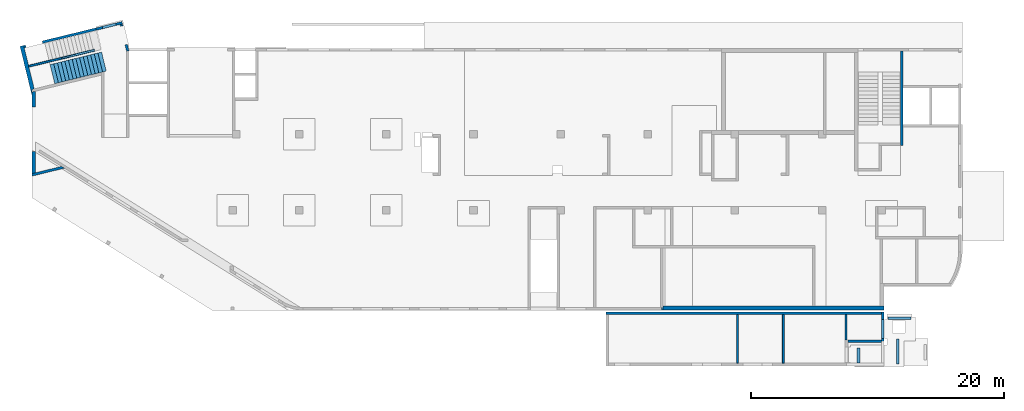
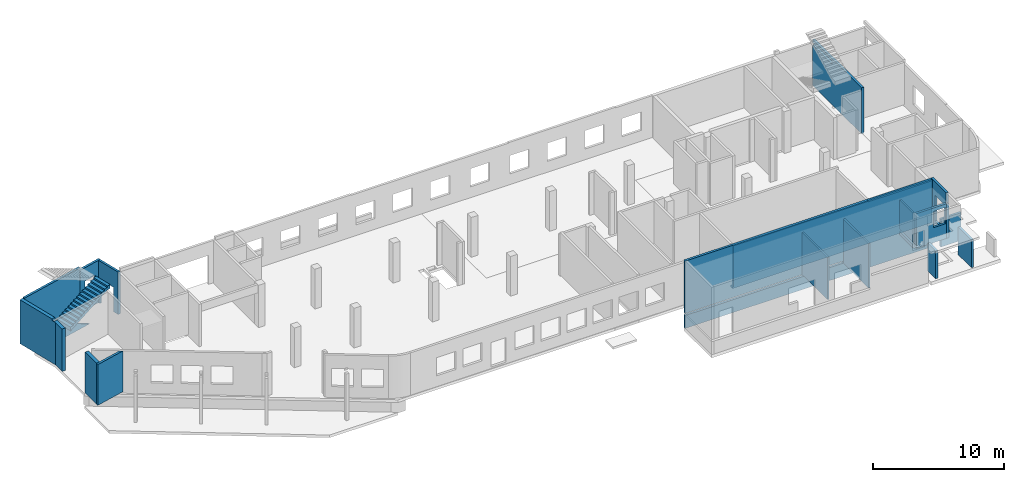
# One storey, part 4 of 8: 19 walls, 1 stair, 7 openings.
"""IFC4 building model written with IfcOpenShell, lengths in millimetres."""

from ifc_helpers import new_model, entity, si_unit, converted_unit, derived_unit, direction, frame, origin, place, context, subcontext, project, spatial, indexed_curve, outline, extrude, polygons, material, type_object, element, save


model = new_model("IFC4")

# Units and contexts
model_context = context("Model", 3, precision=0.01, world=origin(), true_north=direction((6.12303176911189e-17, 1.0)))
plan_context = context("Plan", 3, precision=0.01, world=origin(), true_north=direction((6.12303176911189e-17, 1.0)))
body_context = subcontext(model_context, "Body", "Model", "MODEL_VIEW")
ifc_project = project(units=[si_unit("LENGTHUNIT", "METRE", prefix="MILLI"), si_unit("AREAUNIT", "SQUARE_METRE"), si_unit("VOLUMEUNIT", "CUBIC_METRE"), converted_unit("PLANEANGLEUNIT", "DEGREE", entity("IfcRatioMeasure", 0.0174532925199433), si_unit("PLANEANGLEUNIT", "RADIAN"), dimensions=[0, 0, 0, 0, 0, 0, 0]), si_unit("MASSUNIT", "GRAM", prefix="KILO"), derived_unit("MASSDENSITYUNIT", [(si_unit("MASSUNIT", "GRAM", prefix="KILO"), 1), (si_unit("LENGTHUNIT", "METRE"), -3)]), derived_unit("MOMENTOFINERTIAUNIT", [(si_unit("LENGTHUNIT", "METRE"), 4)]), si_unit("TIMEUNIT", "SECOND"), si_unit("FREQUENCYUNIT", "HERTZ"), si_unit("THERMODYNAMICTEMPERATUREUNIT", "DEGREE_CELSIUS"), derived_unit("THERMALTRANSMITTANCEUNIT", [(si_unit("MASSUNIT", "GRAM", prefix="KILO"), 1), (si_unit("THERMODYNAMICTEMPERATUREUNIT", "KELVIN"), -1), (si_unit("TIMEUNIT", "SECOND"), -3)]), derived_unit("VOLUMETRICFLOWRATEUNIT", [(si_unit("LENGTHUNIT", "METRE"), 3), (si_unit("TIMEUNIT", "SECOND"), -1)]), derived_unit("MASSFLOWRATEUNIT", [(si_unit("MASSUNIT", "GRAM", prefix="KILO"), 1), (si_unit("TIMEUNIT", "SECOND"), -1)]), derived_unit("ROTATIONALFREQUENCYUNIT", [(si_unit("TIMEUNIT", "SECOND"), -1)]), si_unit("ELECTRICCURRENTUNIT", "AMPERE"), si_unit("ELECTRICVOLTAGEUNIT", "VOLT"), si_unit("POWERUNIT", "WATT"), si_unit("FORCEUNIT", "NEWTON", prefix="KILO"), si_unit("ILLUMINANCEUNIT", "LUX"), si_unit("LUMINOUSFLUXUNIT", "LUMEN"), si_unit("LUMINOUSINTENSITYUNIT", "CANDELA"), derived_unit("USERDEFINED", [(si_unit("MASSUNIT", "GRAM", prefix="KILO"), -1), (si_unit("LENGTHUNIT", "METRE"), -2), (si_unit("TIMEUNIT", "SECOND"), 3), (si_unit("LUMINOUSFLUXUNIT", "LUMEN"), 1)]), derived_unit("LINEARVELOCITYUNIT", [(si_unit("LENGTHUNIT", "METRE"), 1), (si_unit("TIMEUNIT", "SECOND"), -1)]), si_unit("PRESSUREUNIT", "PASCAL"), derived_unit("USERDEFINED", [(si_unit("LENGTHUNIT", "METRE"), -2), (si_unit("MASSUNIT", "GRAM", prefix="KILO"), 1), (si_unit("TIMEUNIT", "SECOND"), -2)]), derived_unit("LINEARFORCEUNIT", [(si_unit("MASSUNIT", "GRAM", prefix="KILO"), 1), (si_unit("LENGTHUNIT", "METRE"), 1), (si_unit("TIMEUNIT", "SECOND"), -2), (si_unit("LENGTHUNIT", "METRE"), -1)]), derived_unit("PLANARFORCEUNIT", [(si_unit("MASSUNIT", "GRAM", prefix="KILO"), 1), (si_unit("LENGTHUNIT", "METRE"), 1), (si_unit("TIMEUNIT", "SECOND"), -2), (si_unit("LENGTHUNIT", "METRE"), -2)])], contexts=[model_context, plan_context])

# Site, building, storey
site_placement = place(None, origin())
site = spatial("IfcSite", under=ifc_project, at=site_placement, CompositionType="ELEMENT")
building_placement = place(site_placement, origin())
building = spatial("IfcBuilding", under=site, at=building_placement, CompositionType="ELEMENT")
storey_placement = place(building_placement, origin())
storey = spatial("IfcBuildingStorey", under=building, at=storey_placement, Name="01", CompositionType="ELEMENT", Elevation=0.0)

# Wall
ifc_material_1 = material()
wall_type_1 = type_object("IfcWallType", Name=":ADSK_ 25_200", PredefinedType="STANDARD")
wall_1_placement = place(storey_placement, frame((68870.0, 20300.0, -250.0), z_axis=(0.0, 0.0, 1.0), x_axis=(0.0, -1.0, 0.0)))
element("IfcWall", 1, at=wall_1_placement, inside=storey, type_object=wall_type_1, material=ifc_material_1, Name=":ADSK_ 25_200", ObjectType=":ADSK_ 25_200", PredefinedType="NOTDEFINED", context=body_context, shape_type="Tessellation", body=[
    polygons([(0.0, -99.9999999999859, 0.0), (100.000000000224, -99.9999999999943, 0.0), (7470.00000000022, -99.9999999999983, 0.0), (7470.00000000022, -99.9999999999983, 100.0), (7470.00000000022, -99.9999999999983, 4050.0), (7470.00000000022, -99.9999999999983, 4300.0), (2520.00000000074, -99.9999999999957, 4300.0), (0.0, -99.9999999999859, 4300.0), (0.0, -99.9999999999859, 4030.0), (2930.00000000025, -99.9999999999945, 4030.0), (2930.00000000025, -99.9999999999945, 3780.0), (0.0, -99.9999999999859, 3780.0), (7470.00000000021, 99.9999999999996, 0.0), (100.00000000022, 100.000000000004, 0.0), (-4.33146851719357e-12, 100.000000000003, 0.0), (-4.33146851719357e-12, 100.000000000003, 3780.0), (2930.00000000024, 99.9999999999947, 3780.0), (2930.00000000024, 99.9999999999947, 4030.0), (-4.33146851719357e-12, 100.000000000003, 4030.0), (-4.33146851719357e-12, 100.000000000003, 4300.0), (2520.00000000074, 100.000000000002, 4300.0), (2730.00000000074, 100.000000000003, 4300.0), (2930.00000000074, 100.000000000003, 4300.0), (7470.00000000021, 99.9999999999996, 4300.0)], [[[1, 2, 3, 4, 5, 6, 7, 8, 9, 10, 11, 12]], [[13, 14, 15, 16, 17, 18, 19, 20, 21, 22, 23, 24]], [[3, 2, 1, 15, 14, 13]], [[8, 7, 6, 24, 23, 22, 21, 20]], [[6, 5, 4, 3, 13, 24]], [[11, 17, 16, 12]], [[18, 10, 9, 19]], [[17, 11, 10, 18]], [[15, 1, 12, 16]], [[8, 20, 19, 9]]], closed=True),
])

# Wall, opening
wall_2_placement = place(storey_placement, frame((7154.28, 22536.28, -150.0), z_axis=(0.0, 0.0, 1.0), x_axis=(-0.971552058141473, -0.236826092990337, 0.0)))
wall_2 = element("IfcWall", 2, at=wall_2_placement, inside=storey, type_object=wall_type_1, material=ifc_material_1, Name=":ADSK_ 25_200", ObjectType=":ADSK_ 25_200", PredefinedType="NOTDEFINED", context=body_context, shape_type="Tessellation", body=[
    polygons([(0.0, -99.9999999999989, 0.0), (2130.93783039304, -100.000000000003, 0.0), (2130.93783039304, -100.000000000003, 3950.0), (2129.99999999999, -100.000000000003, 3950.0), (2.16573425859679e-12, -99.9999999999989, 3950.0), (499.999999999999, -100.000000000319, 2700.0), (1600.0, -100.000000000324, 2700.0), (1600.0, -100.000000000324, 1000.00000000001), (499.999999999999, -100.000000000319, 1000.00000000001), (-1.08286712929839e-12, 99.9999999999989, 0.0), (-1.08286712929839e-12, 99.9999999999989, 3950.0), (199.999999999998, 99.9999999999989, 3950.0), (2130.93783039304, 99.9999999999989, 3950.0), (2130.93783039304, 99.9999999999989, 0.0), (199.999999999999, 99.9999999999989, 0.0), (1600.0, 100.000000000003, 2700.0), (499.999999999999, 99.9999999999989, 2700.0), (499.999999999999, 99.9999999999989, 1000.00000000001), (1600.0, 100.000000000003, 1000.00000000001)], [[[1, 2, 3, 4, 5], [6, 7, 8, 9]], [[10, 11, 12, 13, 14, 15], [16, 17, 18, 19]], [[2, 1, 10, 15, 14]], [[3, 2, 14, 13]], [[5, 4, 3, 13, 12, 11]], [[1, 5, 11, 10]], [[7, 6, 17, 16]], [[7, 16, 19, 8]], [[8, 19, 18, 9]], [[17, 6, 9, 18]]], closed=True),
])
opening_1_placement = place(wall_2_placement, frame((12287.93, 20200.85, 150.0), z_axis=(0.0, 0.0, 1.0), x_axis=(-0.971552058141473, 0.236826092990337, 0.0)))
element("IfcOpeningElement", 3, at=opening_1_placement, cuts=wall_2, Name=":ADSK_ 25_200", PredefinedType="OPENING", context=body_context, shape_type="SweptSolid", body=[
    extrude(outline(indexed_curve([(-550.0, -849.999999999994), (550.0, -849.999999999994), (550.0, 849.999999999994), (-550.0, 849.999999999994), (-550.0, -849.999999999994)], self_intersect=False)), frame((6110.47, 22384.77, 1700.0), z_axis=(0.236826092990338, -0.971552058141473, 0.0), x_axis=(-0.971552058141473, -0.236826092990338, 0.0)), (0.0, 0.0, 1.0), 200.000000000964),
])

wall_3_placement = place(storey_placement, frame((7080.81, 22415.44, -150.0), z_axis=(0.0, 0.0, 1.0), x_axis=(0.236826092990336, -0.971552058141473, 0.0)))
wall_3 = element("IfcWall", 4, at=wall_3_placement, inside=storey, type_object=wall_type_1, material=ifc_material_1, Name=":ADSK_ 25_200", ObjectType=":ADSK_ 25_200", PredefinedType="NOTDEFINED", context=body_context, shape_type="Tessellation", body=[
    polygons([(2180.28371765133, -100.000000000001, 3950.0), (8.66293703438714e-12, -100.0, 3950.0), (8.66293703438714e-12, -100.0, 0.0), (149.999999999996, -100.0, 0.0), (149.999999999996, -100.000000000001, 2279.99999999804), (1649.99999999999, -100.000000000001, 2279.99999999805), (1649.99999999999, -100.000000000001, 0.0), (2180.28371765133, -100.000000000001, 0.0), (4.33146851719357e-12, 99.9999999999989, 3950.0), (1995.90425351864, 99.9999999999984, 3950.0), (2201.76043829436, 99.9999999999978, 3950.0), (2204.30804833156, 99.9999999999978, 3950.0), (2204.30804833156, 99.9999999999978, 0.0), (2201.76043829436, 99.9999999999989, 0.0), (1995.90425351865, 99.9999999999995, 0.0), (1649.99999999999, 99.9999999999989, 0.0), (1649.99999999999, 99.9999999999978, 2279.99999999805), (149.999999999992, 99.9999999999978, 2279.99999999804), (149.999999999996, 99.9999999999989, 0.0), (4.33146851719357e-12, 99.9999999999989, 0.0)], [[[1, 2, 3, 4, 5, 6, 7, 8]], [[9, 10, 11, 12, 13, 14, 15, 16, 17, 18, 19, 20]], [[3, 20, 19, 4]], [[2, 1, 12, 11, 10, 9]], [[3, 2, 9, 20]], [[1, 8, 13, 12]], [[17, 6, 5, 18]], [[18, 5, 4, 19]], [[6, 17, 16, 7]], [[13, 8, 7, 16, 15, 14]]], closed=True),
])
opening_2_placement = place(wall_3_placement, frame((20100.85, -12187.93, 150.0), z_axis=(0.0, 0.0, 1.0), x_axis=(0.236826092990336, 0.971552058141473, 0.0)))
element("IfcOpeningElement", 5, at=opening_2_placement, cuts=wall_3, Name=":ADSK_ 25_200", PredefinedType="OPENING", context=body_context, shape_type="SweptSolid", body=[
    extrude(outline(indexed_curve([(-1139.99999999902, -750.000000000002), (1139.99999999902, -750.000000000002), (1139.99999999902, 749.999999999998), (-1139.99999999902, 749.999999999998), (-1139.99999999902, -750.000000000002)], self_intersect=False)), frame((7099.64, 21493.68, 990.0), z_axis=(0.971552058141473, 0.236826092990336, 0.0), x_axis=(0.0, 0.0, -1.0)), (0.0, 0.0, 1.0), 400.000000001945),
])

# Wall
wall_4_placement = place(storey_placement, frame((-23.68, 10483.47, 0.0), z_axis=(0.0, 0.0, 1.0), x_axis=(0.971552058141473, 0.236826092990339, 0.0)))
element("IfcWall", 6, at=wall_4_placement, inside=storey, type_object=wall_type_1, material=ifc_material_1, Name=":ADSK_ 25_200", ObjectType=":ADSK_ 25_200", PredefinedType="NOTDEFINED", context=body_context, shape_type="Tessellation", body=[
    polygons([(0.0, -100.000000000001, 0.0), (2669.79789385161, -100.000000000001, 0.0), (2669.79789385161, -99.9999999999989, 3800.0), (0.0, -100.000000000001, 3800.0), (2474.61779994127, 99.9999999999968, 0.0), (357.536393121908, 99.9999999999989, 0.0), (48.7521159583308, 99.9999999999989, 0.0), (48.7521159583302, 99.9999999999989, 3800.0), (2474.61779994127, 99.9999999999989, 3800.0)], [[[1, 2, 3, 4]], [[5, 6, 7, 8, 9]], [[2, 1, 7, 6, 5]], [[2, 5, 9, 3]], [[7, 1, 4, 8]], [[4, 3, 9, 8]]], closed=True),
])

# Wall, opening
wall_5_placement = place(storey_placement, frame((5083.96, 22031.62, -150.0), z_axis=(0.0, 0.0, 1.0), x_axis=(-0.971552058141473, -0.236826092990335, 0.0)))
wall_5 = element("IfcWall", 7, at=wall_5_placement, inside=storey, type_object=wall_type_1, material=ifc_material_1, Name=":ADSK_ 25_200", ObjectType=":ADSK_ 25_200", PredefinedType="NOTDEFINED", context=body_context, shape_type="Tessellation", body=[
    polygons([(5869.05423926975, -100.000000000003, 4200.0), (-1.08286712929839e-12, -100.000000000003, 4200.0), (-1.08286712929839e-12, -100.000000000003, 3950.0), (-1.08286712929839e-12, -100.000000000003, 0.0), (4369.05423926974, -100.000000000003, 0.0), (4369.05423926974, -100.000000000003, 1400.0), (5719.05423926973, -100.000000000003, 1400.0), (5719.05423926973, -100.000000000003, 0.0), (5869.05423926975, -100.000000000003, 0.0), (5869.05423926975, -100.000000000003, 4100.0), (-2.16573425859679e-12, 99.9999999999989, 4200.0), (5869.05423926975, 99.9999999999989, 4200.0), (5869.05423926975, 99.9999999999989, 0.0), (5719.05423926974, 99.9999999999946, 0.0), (5719.05423926974, 100.000000000311, 1400.0), (4369.05423926974, 100.000000000311, 1400.0), (4369.05423926974, 99.9999999999946, 0.0), (-2.16573425859679e-12, 99.9999999999989, 0.0), (-2.16573425859679e-12, 99.9999999999989, 3950.0)], [[[1, 2, 3, 4, 5, 6, 7, 8, 9, 10]], [[11, 12, 13, 14, 15, 16, 17, 18, 19]], [[4, 18, 17, 5]], [[2, 1, 12, 11]], [[4, 3, 2, 11, 19, 18]], [[15, 7, 6, 16]], [[16, 6, 5, 17]], [[7, 15, 14, 8]], [[1, 10, 9, 13, 12]], [[9, 8, 14, 13]]], closed=True),
])
opening_3_placement = place(wall_5_placement, origin())
element("IfcOpeningElement", 8, at=opening_3_placement, cuts=wall_5, Name=":ADSK_ 25_200", PredefinedType="OPENING", context=body_context, shape_type="SweptSolid", body=[
    extrude(outline(indexed_curve([(-1089.99999999999, -675.0), (1089.99999999999, -675.0), (1089.99999999999, 675.0), (-1089.99999999999, 675.0), (-1089.99999999999, -675.0)], self_intersect=False)), frame((5044.05, -200.0, 310.0), z_axis=(0.0, 1.0, 0.0), x_axis=(0.0, 0.0, -1.0)), (0.0, 0.0, 1.0), 300.000000000971),
])

# Wall
wall_6_placement = place(storey_placement, frame((45470.0, -470.0, -2100.0)))
element("IfcWall", 9, at=wall_6_placement, inside=storey, type_object=wall_type_1, material=ifc_material_1, Name=":ADSK_ 25_200", ObjectType=":ADSK_ 25_200", PredefinedType="NOTDEFINED", context=body_context, shape_type="Tessellation", body=[
    polygons([(0.0, -100.0, 0.0), (199.999999999998, -100.0, 0.0), (21799.9966516707, -100.0, 0.0), (21799.9966516707, -100.0, 6280.0), (199.999999999998, -100.0, 6280.0), (0.0, -100.0, 6280.0), (0.0, -100.0, 1400.0), (199.999999999998, -100.0, 1400.0), (10325.0000000001, -100.0, 1400.0), (10475.0000000001, -100.0, 1400.0), (13955.0000000001, -100.0, 1400.0), (13955.0000000001, -100.0, 1200.0), (199.999999999998, -100.0, 1200.0), (0.0, -100.0, 1200.0), (21799.9966516707, 100.0, 0.0), (0.0, 100.0, 0.0), (0.0, 100.0, 1200.0), (13955.0000000001, 99.9999999999986, 1200.0), (13955.0000000001, 99.9999999999986, 1400.0), (0.0, 100.0, 1400.0), (0.0, 100.0, 6280.0), (21799.9966516707, 100.0, 6280.0), (21799.9966516707, 100.0, 2100.0)], [[[1, 2, 3, 4, 5, 6, 7, 8, 9, 10, 11, 12, 13, 14]], [[15, 16, 17, 18, 19, 20, 21, 22, 23]], [[3, 2, 1, 16, 15]], [[6, 5, 4, 22, 21]], [[6, 21, 20, 7]], [[4, 3, 15, 23, 22]], [[12, 18, 17, 14, 13]], [[19, 11, 10, 9, 8, 7, 20]], [[18, 12, 11, 19]], [[16, 1, 14, 17]]], closed=True),
])

# Wall, opening
wall_7_placement = place(storey_placement, frame((67370.0, -370.0, 0.0), z_axis=(0.0, 0.0, 1.0), x_axis=(0.0, -1.0, 0.0)))
wall_7 = element("IfcWall", 10, at=wall_7_placement, inside=storey, type_object=wall_type_1, material=ifc_material_1, Name=":ADSK_ 25_200", ObjectType=":ADSK_ 25_200", PredefinedType="NOTDEFINED", context=body_context, shape_type="Tessellation", body=[
    polygons([(0.0, -100.000000000004, 0.0), (2199.99992981406, -99.9999999999998, 0.0), (2399.99992981406, -99.9999999999916, 0.0), (2399.99992981406, -99.9999999999916, 3230.0), (2299.99992981406, -99.9999999999914, 3230.0), (2299.99992981406, -99.9999999999914, 4180.0), (200.0, -99.9999999999958, 4180.0), (0.0, -100.000000000004, 4180.0), (600.000055868205, -100.000000000005, 2929.99999999804), (2100.00005586821, -99.999999999991, 2929.99999999804), (2100.00005586821, -99.999999999991, 530.0), (600.000055868206, -100.000000000005, 530.0), (2399.99992981406, 100.000000000006, 0.0), (4.06075173486897e-13, 100.000000000002, 0.0), (4.06075173486897e-13, 100.000000000002, 4180.0), (2299.99992981406, 100.000000000006, 4180.0), (2299.99992981406, 100.000000000006, 3230.0), (2399.99992981406, 100.000000000006, 3230.0), (2100.00005586821, 99.9999999999982, 2929.99999999804), (600.000055868206, 100.000000000001, 2929.99999999804), (600.000055868206, 100.000000000001, 530.0), (2100.00005586821, 99.9999999999982, 530.0)], [[[1, 2, 3, 4, 5, 6, 7, 8], [9, 10, 11, 12]], [[13, 14, 15, 16, 17, 18], [19, 20, 21, 22]], [[3, 2, 1, 14, 13]], [[8, 7, 6, 16, 15]], [[1, 8, 15, 14]], [[16, 6, 5, 17]], [[17, 5, 4, 18]], [[3, 13, 18, 4]], [[9, 20, 19, 10]], [[10, 19, 22, 11]], [[11, 22, 21, 12]], [[20, 9, 12, 21]]], closed=True),
])
opening_4_placement = place(wall_7_placement, frame((-370.0, -67370.0, 0.0), z_axis=(0.0, 0.0, 1.0), x_axis=(0.0, 1.0, 0.0)))
element("IfcOpeningElement", 11, at=opening_4_placement, cuts=wall_7, Name=":ADSK_ 25_200", PredefinedType="OPENING", context=body_context, shape_type="SweptSolid", body=[
    extrude(outline(indexed_curve([(-750.0, -1199.99999999902), (750.0, -1199.99999999902), (750.0, 1199.99999999902), (-750.0, 1199.99999999902), (-750.0, -1199.99999999902)], self_intersect=False)), frame((67170.0, -1720.0, 1730.0), z_axis=(1.0, 0.0, 0.0), x_axis=(0.0, -1.0, 0.0)), (0.0, 0.0, 1.0), 400.000000001936),
])

wall_8_placement = place(storey_placement, frame((64600.0, -2670.0, 0.0)))
wall_8 = element("IfcWall", 12, at=wall_8_placement, inside=storey, type_object=wall_type_1, material=ifc_material_1, Name=":ADSK_ 25_200", ObjectType=":ADSK_ 25_200", PredefinedType="NOTDEFINED", context=body_context, shape_type="Tessellation", body=[
    polygons([(2.20736734168918e-13, -100.0, 0.0), (2669.99665167067, -100.000000000001, 0.0), (2669.99665167067, -100.000000000001, 3230.0), (2.20736734168918e-13, -100.0, 3230.0), (2569.99665167068, -100.0, 2930.0), (2569.99665167068, -100.0, 1400.0), (1519.99665167067, -100.0, 1400.0), (1519.99665167067, -100.0, 2930.0), (-4.20683568093687e-13, 100.0, 0.0), (-4.20683568093687e-13, 100.0, 330.0), (-4.20683568093687e-13, 100.0, 530.0), (-4.20683568093687e-13, 100.0, 3230.0), (2669.99665167065, 99.9999999999995, 3230.0), (2669.99665167065, 99.9999999999995, 0.0), (2569.99665167068, 100.0, 2930.0), (1519.99665167067, 100.0, 2930.0), (1519.99665167067, 100.0, 1400.0), (2569.99665167068, 100.0, 1400.0), (2669.99665167067, -1.62430069394759e-12, 3230.0)], [[[1, 2, 3, 4], [5, 6, 7, 8]], [[9, 10, 11, 12, 13, 14], [15, 16, 17, 18]], [[1, 4, 12, 11, 10, 9]], [[3, 2, 14, 13, 19]], [[4, 3, 19, 13, 12]], [[2, 1, 9, 14]], [[6, 5, 15, 18]], [[7, 6, 18, 17]], [[8, 7, 17, 16]], [[5, 8, 16, 15]]], closed=True),
])
opening_5_placement = place(wall_8_placement, origin())
element("IfcOpeningElement", 13, at=opening_5_placement, cuts=wall_8, Name=":ADSK_ 25_200", PredefinedType="OPENING", context=body_context, shape_type="SweptSolid", body=[
    extrude(outline(indexed_curve([(-525.000000000002, -765.0), (525.000000000002, -765.0), (525.000000000002, 765.0), (-525.000000000002, 765.0), (-525.000000000002, -765.0)], self_intersect=False)), frame((2045.0, 100.0, 2165.0), z_axis=(0.0, -1.0, 0.0), x_axis=(-1.0, 0.0, 0.0)), (0.0, 0.0, 1.0), 200.0),
])

# Walls
wall_9_placement = place(storey_placement, frame((65450.0, -4420.0, -2100.0), z_axis=(0.0, 0.0, 1.0), x_axis=(0.0, 1.0, 0.0)))
element("IfcWall", 14, at=wall_9_placement, inside=storey, type_object=wall_type_1, material=ifc_material_1, Name=":ADSK_ 25_200", ObjectType=":ADSK_ 25_200", PredefinedType="NOTDEFINED", context=body_context, shape_type="Tessellation", body=[
    polygons([(0.0, -99.9999999999946, 0.0), (1225.00005833431, -99.9999999999946, 0.0), (1225.00005833431, -99.9999999999946, 2590.0), (0.0, -99.9999999999946, 2590.0), (5.41433564649196e-13, 99.9999999999946, 0.0), (5.41433564649196e-13, 99.9999999999946, 2590.0), (1225.00005833431, 99.9999999999946, 2590.0), (1225.00005833431, 99.9999999999946, 0.0)], [[[1, 2, 3, 4]], [[5, 6, 7, 8]], [[2, 1, 5, 8]], [[3, 2, 8, 7]], [[1, 4, 6, 5]], [[4, 3, 7, 6]]], closed=True),
])
wall_10_placement = place(storey_placement, frame((68545.01, -4495.0, -2100.0), z_axis=(0.0, 0.0, 1.0), x_axis=(0.0, 1.0, 0.0)))
element("IfcWall", 15, at=wall_10_placement, inside=storey, type_object=wall_type_1, material=ifc_material_1, Name=":ADSK_ 25_200", ObjectType=":ADSK_ 25_200", PredefinedType="NOTDEFINED", context=body_context, shape_type="Tessellation", body=[
    polygons([(0.0, -99.9999999999946, 0.0), (1999.9999865911, -99.9999999999946, 0.0), (1999.9999865911, -99.9999999999946, 2590.0), (0.0, -99.9999999999946, 2590.0), (0.0, 99.9999999999946, 0.0), (0.0, 99.9999999999946, 2590.0), (1999.9999865911, 99.9999999999946, 2590.0), (1999.9999865911, 99.9999999999946, 0.0)], [[[1, 2, 3, 4]], [[5, 6, 7, 8]], [[2, 1, 5, 8]], [[3, 2, 8, 7]], [[1, 4, 6, 5]], [[4, 3, 7, 6]]], closed=True),
])
wall_11_placement = place(storey_placement, frame((67795.0, -855.0, -2100.0)))
element("IfcWall", 16, at=wall_11_placement, inside=storey, type_object=wall_type_1, material=ifc_material_1, Name=":ADSK_ 25_200", ObjectType=":ADSK_ 25_200", PredefinedType="NOTDEFINED", context=body_context, shape_type="Tessellation", body=[
    polygons([(3.08805379778116e-12, -100.0, 0.0), (1800.00000000001, -100.0, 0.0), (1800.00000000001, -100.0, 2590.0), (3.08805379778116e-12, -100.0, 2590.0), (2.44134148445018e-12, 100.0, 0.0), (2.44134151673763e-12, 99.9999900148955, 2590.0), (1800.00000000001, 100.0, 2590.0), (1800.00000000001, 100.0, 0.0)], [[[1, 2, 3, 4]], [[5, 6, 7, 8]], [[2, 1, 5, 8]], [[3, 2, 8, 7]], [[1, 4, 6, 5]], [[4, 3, 7, 6]]], closed=True),
])
wall_type_2 = type_object("IfcWallType", Name=":ADSK_ 25_300", PredefinedType="STANDARD")
wall_12_placement = place(storey_placement, frame((49870.0, -50.0, -150.0)))
element("IfcWall", 17, at=wall_12_placement, inside=storey, type_object=wall_type_2, material=ifc_material_1, Name=":ADSK_ 25_300", ObjectType=":ADSK_ 25_300", PredefinedType="NOTDEFINED", context=body_context, shape_type="Tessellation", body=[
    polygons([(6.46066962494362e-13, -150.0, 0.0), (17600.0, -150.0, 0.0), (17600.0, -150.0, 3900.0), (11950.0, -149.999999999981, 3900.0), (11950.0, -150.0, 3950.0), (99.9999999999952, -150.0, 3950.0), (99.9999999999952, -150.0, 150.0), (6.46066962494362e-13, -150.0, 150.0), (17600.0, 150.0, 0.0), (17300.0, 150.0, 0.0), (12150.0, 150.0, 0.0), (11950.0, 150.0, 0.0), (-3.23029732568751e-13, 150.0, 0.0), (-3.23029732568751e-13, 150.0, 150.0), (99.9999999999943, 150.0, 150.0), (99.9999999999943, 150.0, 3950.0), (3400.00000000001, 150.0, 3950.0), (3600.0, 150.0, 3950.0), (7775.0, 150.0, 3950.0), (7974.99999999999, 150.0, 3950.0), (11950.0, 150.0, 3950.0), (11950.0, 150.000000000001, 3900.0), (12150.0, 150.0, 3900.0), (12850.0, 150.0, 3900.0), (13050.0, 150.0, 3900.0), (17000.0, 150.0, 3900.0), (17200.0, 150.0, 3900.0), (17300.0, 150.0, 3900.0), (17600.0, 150.0, 3900.0), (2.49911895314559e-18, 50.0, 0.0), (99.9999999999946, 50.0, 3950.0), (2.49911895314559e-18, 50.0, 150.0), (99.9999999999946, 50.0, 150.0)], [[[1, 2, 3, 4, 5, 6, 7, 8]], [[9, 10, 11, 12, 13, 14, 15, 16, 17, 18, 19, 20, 21, 22, 23, 24, 25, 26, 27, 28, 29]], [[2, 1, 30, 13, 12, 11, 10, 9]], [[16, 31, 6, 5, 21, 20, 19, 18, 17]], [[2, 9, 29, 3]], [[13, 30, 1, 8, 32, 14]], [[6, 31, 16, 15, 33, 7]], [[22, 4, 3, 29, 28, 27, 26, 25, 24, 23]], [[4, 22, 21, 5]], [[15, 14, 32, 8, 7, 33]]], closed=True),
])

# Wall, opening
wall_13_placement = place(storey_placement, frame((-787.54, 20703.3, -150.0), z_axis=(0.0, 0.0, 1.0), x_axis=(0.236826092990336, -0.971552058141473, 0.0)))
wall_13 = element("IfcWall", 18, at=wall_13_placement, inside=storey, type_object=wall_type_2, material=ifc_material_1, Name=":ADSK_ 25_300", ObjectType=":ADSK_ 25_300", PredefinedType="NOTDEFINED", context=body_context, shape_type="Tessellation", body=[
    polygons([(0.0, -150.000000000002, 0.0), (1620.0, -150.000000000001, 0.0), (3940.77040872537, -150.000000000001, 0.0), (3940.77040872537, -150.000000000002, 3950.0), (3540.00000000001, -150.0, 3950.0), (3540.00000000001, -150.000000000001, 4100.0), (0.0, -150.000000000002, 4100.0), (3540.00000000002, 149.999999999999, 4100.0), (3540.00000000001, 149.999999999999, 2220.0), (3540.00000000001, 149.999999999999, 2020.0), (3540.0, 149.999999999999, 0.0), (1770.0, 149.999999999999, 0.0), (1620.0, 149.999999999999, 0.0), (199.999999999998, 149.999999999999, 0.0), (4.33146851719357e-12, 149.999999999999, 0.0), (4.33146851719357e-12, 149.999999999999, 4100.0), (3540.00000000001, -52.307972805769, 0.0), (3740.00000000001, -101.060088764098, 0.0), (3540.00000000001, -52.3079728057685, 3950.0), (3740.00000000001, -101.060088764098, 3950.0)], [[[1, 2, 3, 4, 5, 6, 7]], [[8, 9, 10, 11, 12, 13, 14, 15, 16]], [[3, 2, 1, 15, 14, 13, 12, 11, 17, 18]], [[16, 7, 6, 8]], [[17, 11, 10, 9, 8, 6, 5, 19]], [[3, 18, 17, 19, 20, 4]], [[1, 7, 16, 15]], [[19, 5, 4, 20]]], closed=True),
])
opening_6_placement = place(wall_13_placement, origin())
element("IfcOpeningElement", 19, at=opening_6_placement, cuts=wall_13, Name=":ADSK_ 25_300", PredefinedType="OPENING", context=body_context, shape_type="SweptSolid", body=[
    extrude(outline(indexed_curve([(-150.000000000483, -1089.99999999999), (150.000000000484, -1089.99999999999), (150.000000000478, 1089.99999999999), (-150.000000000484, 1089.99999999999), (-150.000000000483, -1089.99999999999)], self_intersect=False)), frame((50.0, 300.0, 310.0), z_axis=(0.0, 1.0, 0.0), x_axis=(-1.0, 0.0, 0.0)), (0.0, 0.0, 1.0), 1350.0),
])

# Walls
wall_14_placement = place(storey_placement, frame((150.0, 10592.17, 0.0), z_axis=(0.0, 0.0, 1.0), x_axis=(0.0, 1.0, 0.0)))
element("IfcWall", 20, at=wall_14_placement, inside=storey, type_object=wall_type_2, material=ifc_material_1, Name=":ADSK_ 25_300", ObjectType=":ADSK_ 25_300", PredefinedType="NOTDEFINED", context=body_context, shape_type="Tessellation", body=[
    polygons([(73.1281739374965, -150.0, 0.0), (1742.70851127241, -150.0, 0.0), (1742.70851127241, -150.0, 3800.0), (73.1281739374965, -150.0, 3800.0), (1742.70851127241, 150.0, 0.0), (0.0, 150.0, 0.0), (0.0, 150.0, 3800.0), (1742.70851127241, 150.0, 3800.0), (1742.70851127241, 149.788393424096, 0.0), (1742.70851127241, 149.788393424096, 3800.0)], [[[1, 2, 3, 4]], [[5, 6, 7, 8]], [[2, 1, 6, 5, 9]], [[3, 2, 9, 5, 8, 10]], [[6, 1, 4, 7]], [[4, 3, 10, 8, 7]]], closed=True),
])
wall_15_placement = place(storey_placement, frame((150.0, 15852.46, -150.0), z_axis=(0.0, 0.0, 1.0), x_axis=(0.0, 1.0, 0.0)))
element("IfcWall", 21, at=wall_15_placement, inside=storey, type_object=wall_type_2, material=ifc_material_1, Name=":ADSK_ 25_300", ObjectType=":ADSK_ 25_300", PredefinedType="NOTDEFINED", context=body_context, shape_type="Tessellation", body=[
    polygons([(2.16573425859679e-12, -150.0, 0.0), (1266.43718065428, -150.0, 0.0), (1266.43718065428, -150.0, 3950.0), (2.16573425859679e-12, -150.0, 3950.0), (1193.30900671678, 150.0, 0.0), (986.659854936454, 150.0, 0.0), (2.16573425859679e-12, 150.0, 0.0), (2.16573425859679e-12, 150.0, 3950.0), (986.659854936441, 150.0, 3950.0), (1193.30900671678, 150.0, 3950.0)], [[[1, 2, 3, 4]], [[5, 6, 7, 8, 9, 10]], [[2, 1, 7, 6, 5]], [[7, 1, 4, 8]], [[2, 5, 10, 3]], [[4, 3, 10, 9, 8]]], closed=True),
])
wall_type_3 = type_object("IfcWallType", Name=":ADSK_ 25_150", PredefinedType="STANDARD")
wall_16_placement = place(storey_placement, frame((-240.39, 19092.05, -150.0), z_axis=(0.0, 0.0, 1.0), x_axis=(0.971552058141474, 0.236826092990335, 0.0)))
element("IfcWall", 22, at=wall_16_placement, inside=storey, type_object=wall_type_3, material=ifc_material_1, Name=":ADSK_ 25_150", ObjectType=":ADSK_ 25_150", PredefinedType="NOTDEFINED", context=body_context, shape_type="Tessellation", body=[
    polygons([(1.62430069394759e-12, -74.9999999999981, 0.0), (5362.78640450009, -75.0000000000003, 1.86117787848161e-13), (1322.78640450004, -75.0000000000024, 2020.0), (0.0, -75.0000000000024, 2020.0), (1.62430069394759e-12, 75.0000000000024, 0.0), (0.0, 75.0000000000003, 2020.0), (1322.78640450005, 75.0000000000003, 2020.0), (5362.78640450009, 75.0000000000003, 1.86117787848161e-13)], [[[1, 2, 3, 4]], [[5, 6, 7, 8]], [[1, 4, 6, 5]], [[2, 1, 5, 8]], [[3, 2, 8, 7]], [[4, 3, 7, 6]]], closed=True),
])
wall_17_placement = place(storey_placement, frame((55870.0, -4420.0, -700.0), z_axis=(0.0, 0.0, 1.0), x_axis=(0.0, 1.0, 0.0)))
element("IfcWall", 23, at=wall_17_placement, inside=storey, type_object=wall_type_3, material=ifc_material_1, Name=":ADSK_ 25_150", ObjectType=":ADSK_ 25_150", PredefinedType="NOTDEFINED", context=body_context, shape_type="Tessellation", body=[
    polygons([(0.0, -75.0000000000016, 0.0), (3850.00000000003, -75.0000000000016, 0.0), (3850.00000000003, -75.0000000000016, 3930.0), (0.0, -75.0000000000016, 3930.0), (0.0, 74.999999999999, 0.0), (0.0, 74.999999999999, 3930.0), (3850.00000000003, 74.999999999999, 3930.0), (3850.00000000003, 74.999999999999, 0.0)], [[[1, 2, 3, 4]], [[5, 6, 7, 8]], [[2, 1, 5, 8]], [[3, 2, 8, 7]], [[1, 4, 6, 5]], [[4, 3, 7, 6]]], closed=True),
])
wall_18_placement = place(storey_placement, frame((59500.0, -4420.0, -900.0), z_axis=(0.0, 0.0, 1.0), x_axis=(0.0, 1.0, 0.0)))
element("IfcWall", 24, at=wall_18_placement, inside=storey, type_object=wall_type_3, material=ifc_material_1, Name=":ADSK_ 25_150", ObjectType=":ADSK_ 25_150", PredefinedType="NOTDEFINED", context=body_context, shape_type="Tessellation", body=[
    polygons([(5.41433564649196e-13, -75.0000000000016, 0.0), (3850.00000000003, -75.0000000000016, 0.0), (3850.00000000003, -75.0000000000016, 4130.0), (5.41433564649196e-13, -75.0000000000016, 4130.0), (5.41433564649196e-13, -75.0000000000016, 1430.0), (5.41433564649196e-13, -75.0000000000016, 1230.0), (0.0, 74.999999999999, 0.0), (0.0, 74.999999999999, 200.0), (0.0, 74.999999999999, 4130.0), (3850.00000000003, 74.999999999999, 4130.0), (3850.00000000003, 74.999999999999, 200.0), (3850.00000000003, 74.999999999999, 0.0)], [[[1, 2, 3, 4, 5, 6]], [[7, 8, 9, 10, 11, 12]], [[2, 1, 7, 12]], [[3, 2, 12, 11, 10]], [[1, 6, 5, 4, 9, 8, 7]], [[4, 3, 10, 9]]], closed=True),
])

# Wall, opening
placement = place(storey_placement, frame((64475.0, -570.0, 0.0), z_axis=(0.0, 0.0, 1.0), x_axis=(0.0, -1.0, 0.0)))
wall_19 = element("IfcWall", 25, at=placement, inside=storey, type_object=wall_type_3, material=ifc_material_1, Name=":ADSK_ 25_150", ObjectType=":ADSK_ 25_150", PredefinedType="NOTDEFINED", context=body_context, shape_type="Tessellation", body=[
    polygons([(0.0, -75.0000000000003, 0.0), (1999.99992981405, -75.0000000000003, 0.0), (1999.99992981405, -75.0000000000003, 330.0), (0.0, -75.0000000000003, 330.0), (1999.99992981405, 75.0000000000003, 0.0), (0.0, 75.0000000000003, 0.0), (0.0, 75.0000000000003, 330.0), (1999.99992981405, 75.0000000000003, 330.0)], [[[1, 2, 3, 4]], [[5, 6, 7, 8]], [[2, 1, 6, 5]], [[2, 5, 8, 3]], [[6, 1, 4, 7]], [[4, 3, 8, 7]]], closed=True),
    polygons([(1999.99992981405, -75.0000000000003, 530.0), (0.0, -75.0000000000003, 530.0), (0.0, 75.0000000000003, 530.0), (1999.99992981405, 75.0000000000003, 530.0), (0.0, -75.0000000000003, 3230.0), (1999.99992981405, -75.0000000000003, 3230.0), (1999.99992981405, 75.0000000000003, 3230.0), (0.0, 75.0000000000003, 3230.0)], [[[1, 2, 3, 4]], [[5, 6, 7, 8]], [[5, 8, 3, 2]], [[7, 6, 1, 4]], [[8, 7, 4, 3]], [[6, 5, 2, 1]]], closed=True),
])
element("IfcOpeningElement", 26, at=placement, cuts=wall_19, Name=":ADSK_ 25_150:1", PredefinedType="OPENING", context=body_context, shape_type="SweptSolid", body=[
    extrude(outline(indexed_curve([(-999.999964907026, -75.0000000000003), (999.999964907026, -75.0000000000003), (999.999964907026, 75.0000000000003), (-999.999964907026, 75.0000000000003), (-999.999964907026, -75.0000000000003)], self_intersect=False)), frame((1000.0, 0.0, 330.0)), (0.0, 0.0, 1.0), 200.0),
])

# Stair
ifc_material_2 = material()
stair_type = type_object("IfcStairType", Name="34: 34", PredefinedType="HALF_TURN_STAIR")
stair_placement = place(storey_placement, origin())
element("IfcStair", 27, at=stair_placement, inside=storey, type_object=stair_type, material=ifc_material_2, Name="34: 34", ObjectType="34: 34", PredefinedType="HALF_TURN_STAIR", context=body_context, shape_type="SweptSolid", body=[
    extrude(outline(indexed_curve([(-2092.32535407269, -930.0), (-2092.32535407269, -1280.0), (-2045.11175857273, -1280.0), (1814.88824142724, 649.999999999966), (2107.66671559009, 649.999999999966), (2107.6667155901, 1020.0), (1807.67464592736, 1020.0), (1807.67464592736, 870.000000000003), (1507.67464592735, 870.000000000003), (1507.67464592735, 720.000000000003), (1207.67464592735, 720.000000000003), (1207.67464592735, 570.000000000003), (907.674645927345, 570.000000000002), (907.674645927344, 420.000000000002), (607.67464592734, 420.000000000002), (607.67464592734, 270.000000000002), (307.674645927336, 270.000000000002), (307.674645927335, 120.000000000002), (7.67464592733123, 120.000000000001), (7.67464592733001, -29.9999999999987), (-292.325354072673, -29.9999999999989), (-292.325354072673, -179.999999999999), (-592.325354072676, -179.999999999999), (-592.325354072678, -329.999999999999), (-892.325354072679, -329.999999999999), (-892.32535407268, -479.999999999999), (-1192.32535407268, -480.0), (-1192.32535407268, -630.0), (-1492.32535407268, -630.0), (-1492.32535407268, -780.0), (-1792.32535407269, -780.0), (-1792.32535407269, -930.0), (-2092.32535407269, -930.0)], self_intersect=False)), frame((3847.11, 18209.98, 3150.0), z_axis=(0.236826092990333, -0.971552058141474, 0.0), x_axis=(0.971552058141474, 0.236826092990333, 0.0)), (0.0, 0.0, -1.0), 1550.0),
])

save(model, "model.ifc")
